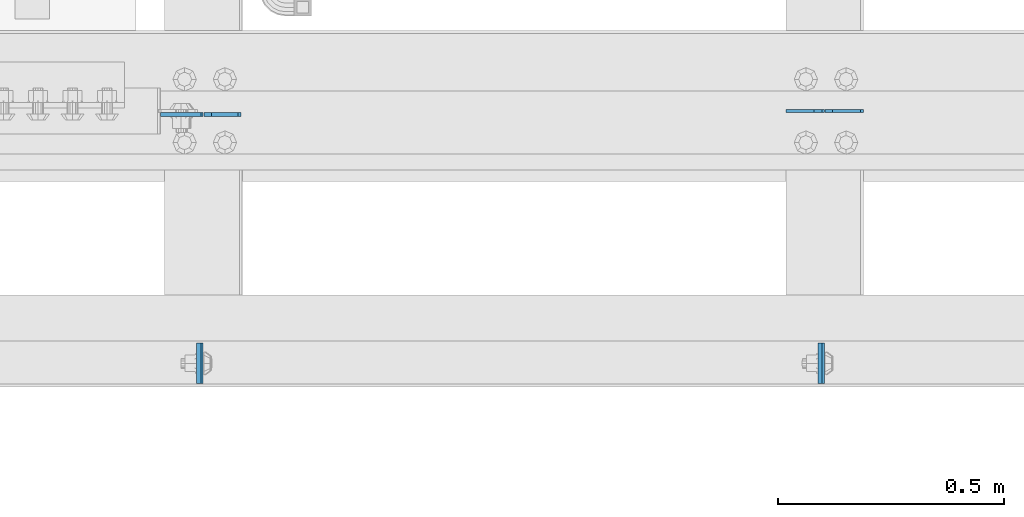
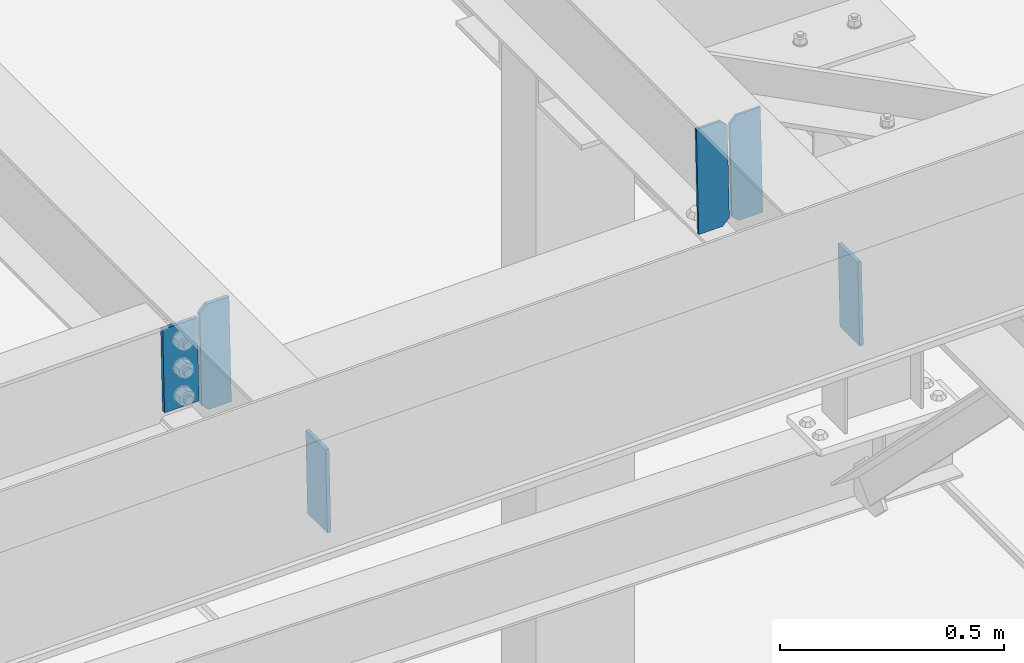
# One storey, part 3025 of 3843: 6 plates, 3 elements without a shape of their own.
"""IFC2X3 building model written with IfcOpenShell, lengths in millimetres."""

from ifc_helpers import new_model, si_unit, frame, origin_with_axes, place, context, subcontext, project, spatial, faceted_brep, material, type_object, element, aggregate, save


model = new_model("IFC2X3")

# Units and contexts
model_context = context("Model", 3, precision=1e-05, world=origin_with_axes())
body_context = subcontext(model_context, "Body", "Model", "MODEL_VIEW")
ifc_project = project(units=[si_unit("LENGTHUNIT", "METRE", prefix="MILLI"), si_unit("AREAUNIT", "SQUARE_METRE"), si_unit("VOLUMEUNIT", "CUBIC_METRE"), si_unit("MASSUNIT", "GRAM", prefix="KILO"), si_unit("TIMEUNIT", "SECOND"), si_unit("PLANEANGLEUNIT", "RADIAN"), si_unit("SOLIDANGLEUNIT", "STERADIAN"), si_unit("THERMODYNAMICTEMPERATUREUNIT", "DEGREE_CELSIUS"), si_unit("LUMINOUSINTENSITYUNIT", "LUMEN")], contexts=[model_context])

# Site, building, storey
site_placement = place(None, origin_with_axes())
site = spatial("IfcSite", under=ifc_project, at=site_placement, CompositionType="ELEMENT")
building_placement = place(site_placement, origin_with_axes())
building = spatial("IfcBuilding", under=site, at=building_placement, Name="Undefined", CompositionType="ELEMENT")
storey_placement = place(building_placement, origin_with_axes())
storey = spatial("IfcBuildingStorey", under=building, at=storey_placement, Name="Undefined", CompositionType="ELEMENT", Elevation=0.0)

# Assembly, plates
assembly_1_placement = place(storey_placement, origin_with_axes())
assembly_1 = element("IfcElementAssembly", 1, at=assembly_1_placement, inside=storey, Name="BEAM", AssemblyPlace="NOTDEFINED", PredefinedType="RIGID_FRAME")
ifc_material = material(Name="STEEL/A572-50")
plate_type_1 = type_object("IfcPlateType", PredefinedType="NOTDEFINED")
plate_1_placement = place(assembly_1_placement, frame((39305.5025242193, 25014.2374900694, 45749.2415750776), z_axis=(0.0, 1.0, 0.0), x_axis=(0.0211520550054438, 0.0, -0.999776270257025)))
plate_1 = element("IfcPlate", 2, at=plate_1_placement, type_object=plate_type_1, material=ifc_material, Name="PLATE", context=body_context, shape_type="Brep", body=[
    faceted_brep([(0.0, -4.76249999999709, 0.0), (0.0, -4.76249999999709, 88.9000015258789), (0.0, 4.76249999999709, 88.9000015258789), (0.0, 4.76249999999709, 0.0), (228.600006102781, -4.7625000004191, 88.9000015257589), (228.600006102781, 4.76249999954598, 88.9000015257443), (228.600006103079, -4.7625000004482, 7.27595761418343e-12), (228.600006103079, 4.76249999954598, -7.27595761418343e-12)], [[[0, 1, 2, 3]], [[1, 4, 5, 2]], [[4, 6, 7, 5]], [[6, 0, 3, 7]], [[5, 7, 3, 2]], [[6, 4, 1, 0]]]),
])
plate_2_placement = place(assembly_1_placement, frame((37933.8956098557, 25014.2375051202, 45720.2187946642), z_axis=(0.0, 1.0, 0.0), x_axis=(0.0211520550054438, 0.0, -0.999776270257025)))
plate_2 = element("IfcPlate", 3, at=plate_2_placement, type_object=plate_type_1, material=ifc_material, Name="PLATE", context=body_context, shape_type="Brep", body=[
    faceted_brep([(0.0, -4.76249999999709, 0.0), (0.0, -4.76249999999709, 88.9000015258789), (0.0, 4.76249999999709, 88.9000015258789), (0.0, 4.76249999999709, 0.0), (228.600006102781, -4.7625000004191, 88.9000015257589), (228.600006102781, 4.76249999954598, 88.9000015257443), (228.600006103079, -4.7625000004482, 7.27595761418343e-12), (228.600006103079, 4.76249999954598, -7.27595761418343e-12)], [[[0, 1, 2, 3]], [[1, 4, 5, 2]], [[4, 6, 7, 5]], [[6, 0, 3, 7]], [[5, 7, 3, 2]], [[6, 4, 1, 0]]]),
])
aggregate(assembly_1, [plate_1, plate_2])

# Assembly, plate
assembly_2_placement = place(storey_placement, origin_with_axes())
assembly_2 = element("IfcElementAssembly", 4, at=assembly_2_placement, inside=storey, Name="BEAM", AssemblyPlace="NOTDEFINED", PredefinedType="RIGID_FRAME")
plate_3_placement = place(assembly_2_placement, frame((37938.6503405883, 25607.9607601098, 45720.3154668948), z_axis=(-0.999776269345987, 1.58400000145775e-06, -0.021152098007311), x_axis=(0.0211520550054438, 0.0, -0.999776270257025)))
plate_3 = element("IfcPlate", 5, at=plate_3_placement, type_object=plate_type_1, material=ifc_material, Name="PLATE", context=body_context, shape_type="Brep", body=[
    faceted_brep([(0.0, -4.76249999999709, 0.0), (0.0, -4.76249999999709, 88.9000015258789), (0.0, 4.76249999999709, 88.9000015258789), (0.0, 4.76249999999709, 0.0), (228.600006102781, -4.7625000004191, 88.9000015257589), (228.600006102781, 4.76249999954598, 88.9000015257443), (228.600006103079, -4.7625000004482, 7.27595761418343e-12), (228.600006103079, 4.76249999954598, -7.27595761418343e-12)], [[[0, 1, 2, 3]], [[1, 4, 5, 2]], [[4, 6, 7, 5]], [[6, 0, 3, 7]], [[5, 7, 3, 2]], [[6, 4, 1, 0]]]),
])

# Assembly, plates
assembly_3_placement = place(storey_placement, origin_with_axes())
assembly_3 = element("IfcElementAssembly", 6, at=assembly_3_placement, inside=storey, Name="BEAM", AssemblyPlace="NOTDEFINED", PredefinedType="RIGID_FRAME")
plate_type_2 = type_object("IfcPlateType", PredefinedType="NOTDEFINED")
plate_4_placement = place(assembly_3_placement, frame((39401.4964782646, 25615.9661872926, 45489.3598286047), z_axis=(-0.0211520982443181, -0.000149703000020964, 0.999776258134226), x_axis=(-0.999776269342228, 3.1669999978437e-06, -0.0211520980072307)))
plate_4 = element("IfcPlate", 7, at=plate_4_placement, type_object=plate_type_2, material=ifc_material, Name="STIFFENER", context=body_context, shape_type="Brep", body=[
    faceted_brep([(0.0, -3.17499999999927, 0.0), (6.83940015733242e-10, -3.17499999996653, 288.924999998613), (6.54836185276508e-10, 3.17500000001746, 288.924999998591), (0.0, 3.17499999999927, 0.0), (61.9125003828667, -3.17499999997744, 288.924999998599), (61.9125003828522, 3.17500000002838, 288.924999998584), (79.3750000013097, -3.17499999997744, 271.462500380039), (79.375000001266, 3.17500000002838, 271.462500380017), (79.375000000713, -3.17499999999927, 17.4624996185448), (79.3750000006694, 3.17500000000291, 17.462499618523), (61.9125003821828, -3.17499999999563, -1.45519152283669e-11), (61.9125003821682, 3.17500000000655, -2.91038304567337e-11)], [[[0, 1, 2, 3]], [[1, 4, 5, 2]], [[4, 6, 7, 5]], [[6, 8, 9, 7]], [[8, 10, 11, 9]], [[10, 0, 3, 11]], [[5, 7, 9, 11, 3, 2]], [[10, 8, 6, 4, 1, 0]]]),
])
plate_5_placement = place(assembly_3_placement, frame((39315.7906575749, 25615.9664588039, 45487.5465650238), z_axis=(-0.0211520982443181, -0.000149703000020964, 0.999776258134226), x_axis=(-0.999776269342228, 3.1669999978437e-06, -0.0211520980072307)))
plate_5 = element("IfcPlate", 8, at=plate_5_placement, type_object=plate_type_2, material=ifc_material, Name="STIFFENER", context=body_context, shape_type="Brep", body=[
    faceted_brep([(5.82076609134674e-11, -3.17499999999927, 17.4624996185667), (6.25732354819775e-10, -3.17499999997744, 271.462500380054), (5.82076609134674e-10, 3.17500000002474, 271.462500380039), (0.0, 3.17500000000655, 17.4624996185521), (17.462499619156, -3.17499999997744, 288.924999998606), (17.4624996191269, 3.17500000002474, 288.924999998591), (79.3750000013242, -3.17500000025029, 288.924999998591), (79.3750000013097, 3.1749999997337, 288.92499999857), (79.3750000006548, -3.17500000026484, -2.18278728425503e-11), (79.3750000006403, 3.17499999969732, -2.91038304567337e-11), (17.4624996184866, -3.17500000000291, 7.27595761418343e-12), (17.462499618443, 3.17500000000291, -7.27595761418343e-12)], [[[0, 1, 2, 3]], [[1, 4, 5, 2]], [[4, 6, 7, 5]], [[6, 8, 9, 7]], [[8, 10, 11, 9]], [[10, 0, 3, 11]], [[5, 7, 9, 11, 3, 2]], [[10, 8, 6, 4, 1, 0]]]),
])
aggregate(assembly_3, [plate_4, plate_5])

# Plate
plate_type_3 = type_object("IfcPlateType", PredefinedType="NOTDEFINED")
plate_6_placement = place(assembly_2_placement, frame((37950.8328191098, 25607.9602496188, 45458.9224429773), z_axis=(-0.0211520980073474, 0.0, 0.999776269347241), x_axis=(0.999776269345987, -1.58399998711222e-06, 0.0211520980073308)))
plate_6 = element("IfcPlate", 9, at=plate_6_placement, type_object=plate_type_3, material=ifc_material, Name="PLATE", context=body_context, shape_type="Brep", body=[
    faceted_brep([(-1.45519152283669e-11, -4.76250000000073, 17.4624996184939), (-2.19733919948339e-09, -4.76249999999709, 270.861788237664), (-2.22644302994013e-09, 4.76250000001164, 270.861788237657), (-1.45519152283669e-11, 4.76250000000073, 17.4624996184939), (17.4624996161801, -4.76249999990978, 288.324287856165), (17.462499616151, 4.76250000009895, 288.324287856158), (76.1999999973414, -4.76249999961874, 288.32428785615), (76.1999999973123, 4.76250000038999, 288.324287856143), (76.2000000012922, -4.76250000000073, 7.27595761418343e-11), (76.2000000012922, 4.76250000000073, 7.27595761418343e-11), (17.4624996186321, -4.76250000000073, 7.27595761418343e-12), (17.4624996186321, 4.76250000000073, 7.27595761418343e-12)], [[[0, 1, 2, 3]], [[1, 4, 5, 2]], [[4, 6, 7, 5]], [[6, 8, 9, 7]], [[8, 10, 11, 9]], [[10, 0, 3, 11]], [[5, 7, 9, 11, 3, 2]], [[10, 8, 6, 4, 1, 0]]]),
])

aggregate(assembly_2, [plate_6, plate_3])

save(model, "model.ifc")
